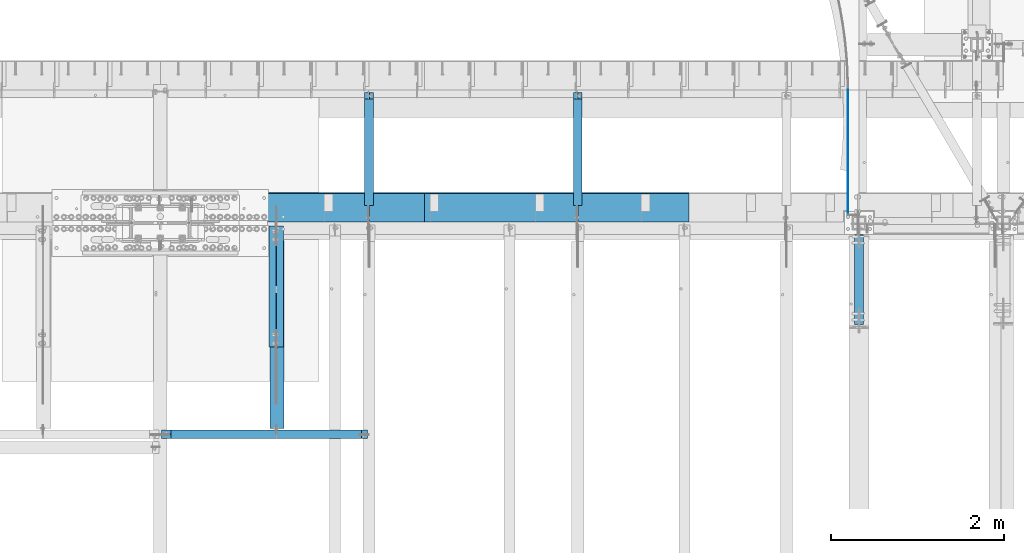
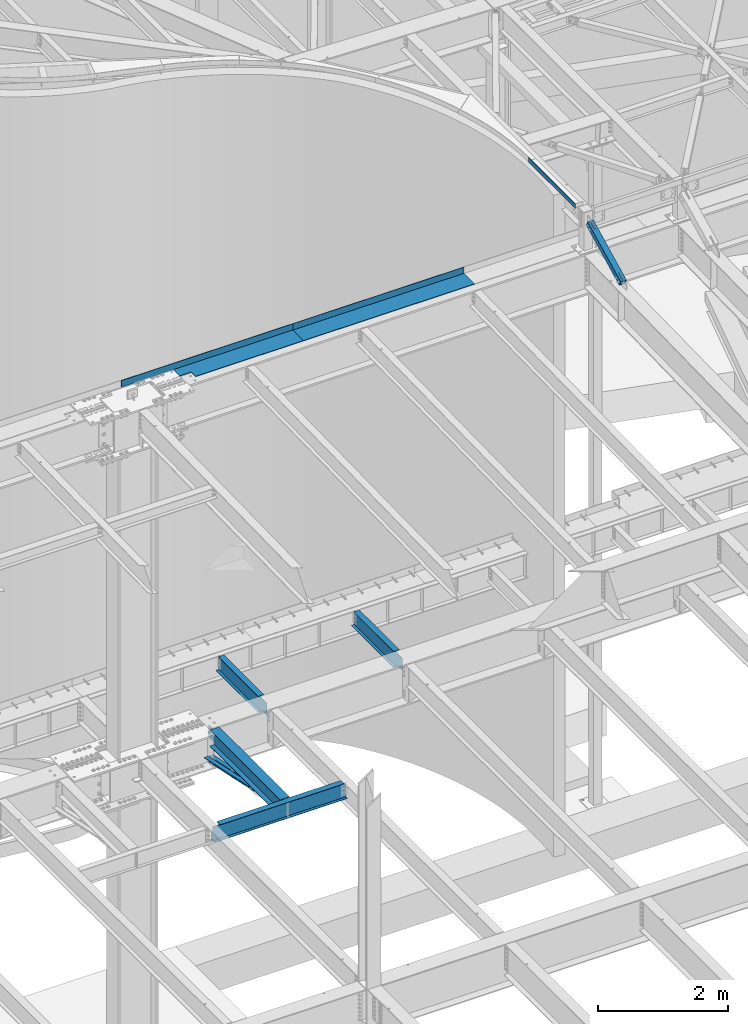
# One storey, part 1141 of 1763: 9 beams, 1 member, 8 elements without a shape of their own.
"""IFC2X3 building model written with IfcOpenShell, lengths in millimetres."""

from ifc_helpers import new_model, si_unit, frame, origin_with_axes, place, context, subcontext, project, spatial, faceted_brep, material, type_object, element, aggregate, save


model = new_model("IFC2X3")

# Units and contexts
model_context = context("Model", 3, precision=1e-05, world=origin_with_axes())
body_context = subcontext(model_context, "Body", "Model", "MODEL_VIEW")
ifc_project = project(units=[si_unit("LENGTHUNIT", "METRE", prefix="MILLI"), si_unit("AREAUNIT", "SQUARE_METRE"), si_unit("VOLUMEUNIT", "CUBIC_METRE"), si_unit("MASSUNIT", "GRAM", prefix="KILO"), si_unit("TIMEUNIT", "SECOND"), si_unit("PLANEANGLEUNIT", "RADIAN"), si_unit("SOLIDANGLEUNIT", "STERADIAN"), si_unit("THERMODYNAMICTEMPERATUREUNIT", "DEGREE_CELSIUS"), si_unit("LUMINOUSINTENSITYUNIT", "LUMEN")], contexts=[model_context])

# Site, building, storey
site_placement = place(None, origin_with_axes())
site = spatial("IfcSite", under=ifc_project, at=site_placement, CompositionType="ELEMENT")
building_placement = place(site_placement, origin_with_axes())
building = spatial("IfcBuilding", under=site, at=building_placement, Name="Undefined", CompositionType="ELEMENT")
storey_placement = place(building_placement, origin_with_axes())
storey = spatial("IfcBuildingStorey", under=building, at=storey_placement, Name="Undefined", CompositionType="ELEMENT", Elevation=0.0)

# Assembly, beam
assembly_1_placement = place(storey_placement, origin_with_axes())
assembly_1 = element("IfcElementAssembly", 1, at=assembly_1_placement, inside=storey, Name="BEAM", AssemblyPlace="NOTDEFINED", PredefinedType="RIGID_FRAME")
ifc_material_1 = material(Name="STEEL/A36")
beam_type_1 = type_object("IfcBeamType", PredefinedType="NOTDEFINED")
beam_1_placement = place(assembly_1_placement, frame((-41466.5130411433, 52209.6785679558, 12526.764063), z_axis=(0.0, 0.0, 1.0), x_axis=(0.0, 1.0, 0.0)))
beam_1 = element("IfcBeam", 2, at=beam_1_placement, type_object=beam_type_1, material=ifc_material_1, Name="PLATE", context=body_context, shape_type="Brep", body=[
    faceted_brep([(0.0, 3.17500000000291, -44.4500000000007), (0.0, 3.17500000000291, 44.4500000000007), (1448.55603526433, 3.17500000000291, 44.4500000000007), (1448.55603526433, 3.17500000000291, -44.4500000000007), (0.0, -3.17500000000291, 44.4500000000007), (1448.55603526433, -3.17500000000291, 44.4500000000007), (0.0, -3.17500000000291, -44.4500000000007), (1448.55603526433, -3.17500000000291, -44.4500000000007)], [[[0, 1, 2, 3]], [[1, 4, 5, 2]], [[4, 6, 7, 5]], [[6, 0, 3, 7]], [[5, 7, 3, 2]], [[6, 4, 1, 0]]]),
])
aggregate(assembly_1, [beam_1])

# Assembly, member
assembly_2_placement = place(storey_placement, origin_with_axes())
assembly_2 = element("IfcElementAssembly", 3, at=assembly_2_placement, inside=storey, Name="BEAM", AssemblyPlace="NOTDEFINED", PredefinedType="RIGID_FRAME")
ifc_material_2 = material()
member_type = type_object("IfcMemberType", Name="HSS4X4X1/2", PredefinedType="NOTDEFINED")
member_placement = place(assembly_2_placement, frame((-41338.5382217802, 50822.4448748991, 11720.6374724137), z_axis=(-1.0, 0.0, 0.0), x_axis=(0.0, 0.894427191199916, 0.447213595099959)))
member = element("IfcMember", 4, at=member_placement, type_object=member_type, material=ifc_material_2, Name="BEAM", ObjectType="HSS4X4X1/2", context=body_context, shape_type="Brep", body=[
    faceted_brep([(1312.61289971653, -50.8000000018983, -7.9375), (1312.61289971651, -38.1000000018903, -7.9375), (1161.80039971038, -38.1000000016793, -7.9375), (1161.8003997104, -50.8000000016891, -7.9375), (1158.762849966, -38.1000000016738, -7.33329378931012), (1158.76284996603, -50.8000000016782, -7.33329378931012), (1156.18773963476, -38.1000000016684, -5.61266007566883), (1156.18773963477, -50.8000000016764, -5.61266007566883), (1154.46710592113, -38.1000000016629, -3.03754974439653), (1154.46710592115, -50.8000000016727, -3.03754974439653), (1153.86289971044, -38.1000000016684, 0.0), (1153.86289971046, -50.8000000016746, 0.0), (1154.46710592113, -38.1000000016629, 3.03754974439653), (1154.46710592115, -50.8000000016727, 3.03754974439653), (1156.18773963476, -38.1000000016684, 5.61266007566883), (1156.18773963477, -50.8000000016764, 5.61266007566883), (1158.762849966, -38.1000000016738, 7.33329378931012), (1158.76284996603, -50.8000000016782, 7.33329378931012), (1161.80039971038, -38.1000000016793, 7.9375), (1161.8003997104, -50.8000000016891, 7.9375), (1312.61289971653, -50.8000000018983, 7.9375), (1312.61289971651, -38.1000000018903, 7.9375), (1312.61289971639, 38.0999999981505, -7.9375), (1312.61289971636, 50.7999999981585, -7.9375), (1161.80039971021, 50.7999999983731, -7.9375), (1161.80039971024, 38.0999999983687, -7.9375), (1158.76284996585, 50.7999999983786, -7.33329378931012), (1158.76284996586, 38.0999999983705, -7.33329378931012), (1156.18773963459, 50.7999999983804, -5.61266007566883), (1156.18773963462, 38.099999998376, -5.61266007566883), (1154.46710592096, 50.7999999983858, -3.03754974439653), (1154.46710592099, 38.0999999983778, -3.03754974439653), (1153.86289971027, 50.7999999983858, 0.0), (1153.86289971031, 38.0999999983796, 0.0), (1154.46710592096, 50.7999999983858, 3.03754974439653), (1154.46710592099, 38.0999999983778, 3.03754974439653), (1156.18773963459, 50.7999999983804, 5.61266007566883), (1156.18773963462, 38.099999998376, 5.61266007566883), (1158.76284996585, 50.7999999983786, 7.33329378931012), (1158.76284996586, 38.0999999983705, 7.33329378931012), (1161.80039971021, 50.7999999983731, 7.9375), (1161.80039971024, 38.0999999983687, 7.9375), (1312.61289971639, 38.0999999981505, 7.9375), (1312.61289971636, 50.7999999981585, 7.9375), (166.342448712407, -38.100000000255, 38.0999999999985), (166.342448712276, 38.0999999997875, 38.0999999999985), (1312.61289971639, 38.0999999981505, 38.0999999999985), (1312.61289971651, -38.1000000018903, 38.0999999999985), (322.767606017376, -38.1000000004806, 5.61266007592349), (320.192495686126, -38.1000000004788, 7.33329378956478), (317.154945941751, -38.1000000004733, 7.93750000025466), (166.342448712407, -38.100000000255, 7.93750000025466), (1312.61289971651, -38.1000000018903, -38.0999999999985), (166.342448712407, -38.100000000255, -38.0999999999985), (166.342448712407, -38.100000000255, -7.93749999974898), (317.154945941751, -38.1000000004715, -7.93749999987267), (320.192495686126, -38.1000000004769, -7.33329378918279), (322.767606017376, -38.1000000004806, -5.61266007554514), (324.488239731007, -38.1000000004842, -3.03754974427284), (325.092445941693, -38.1000000004842, 2.5465851649642e-10), (324.488239731007, -38.1000000004842, 3.03754974465119), (166.342448712276, 38.0999999997875, -38.0999999999985), (1312.61289971639, 38.0999999981505, -38.0999999999985), (166.342448712276, 38.0999999997875, 7.93750000025466), (166.342448712254, 50.7999999997955, 7.93750000025466), (317.154945941591, 50.7999999995791, 7.93750000025466), (317.15494594162, 38.0999999995711, 7.93750000025466), (320.192495685966, 50.7999999995736, 7.33329378956478), (320.192495685995, 38.0999999995693, 7.33329378956478), (322.767606017216, 50.7999999995718, 5.61266007592349), (322.767606017245, 38.0999999995638, 5.61266007592349), (324.488239730847, 50.7999999995682, 3.03754974465119), (324.488239730868, 38.0999999995638, 3.03754974465119), (325.092445941533, 50.7999999995682, 2.5465851649642e-10), (325.092445941555, 38.0999999995583, 2.5465851649642e-10), (324.488239730847, 50.7999999995682, -3.03754974427284), (324.488239730861, 38.0999999995602, -3.03754974427284), (322.767606017209, 50.79999999957, -5.61266007554514), (322.767606017245, 38.0999999995638, -5.61266007554514), (320.192495685966, 50.7999999995754, -7.33329378918279), (320.19249568598, 38.0999999995674, -7.33329378918279), (317.154945941591, 50.7999999995791, -7.93749999987267), (317.154945941606, 38.0999999995693, -7.93749999987267), (166.342448712254, 50.7999999997955, -7.93749999974898), (166.342448712276, 38.0999999997875, -7.93749999974898), (166.342448712254, 50.7999999997955, -50.7999999999993), (166.342448712421, -50.8000000002612, -50.7999999999993), (166.342448712421, -50.8000000002612, -7.93749999974898), (317.154945941773, -50.8000000004795, -7.93749999987267), (320.192495686155, -50.8000000004831, -7.33329378918279), (322.767606017391, -50.8000000004868, -5.61266007554514), (324.488239731028, -50.800000000494, -3.03754974427284), (325.092445941715, -50.8000000004904, 2.5465851649642e-10), (324.488239731028, -50.800000000494, 3.03754974465119), (322.767606017405, -50.8000000004849, 5.61266007592349), (320.192495686155, -50.8000000004849, 7.33329378956478), (317.154945941787, -50.8000000004795, 7.93750000025466), (166.342448712421, -50.8000000002612, 7.93750000025466), (166.342448712421, -50.8000000002612, 50.7999999999993), (166.342448712254, 50.7999999997955, 50.7999999999993), (1312.61289971653, -50.8000000018983, 50.7999999999993), (1312.61289971636, 50.7999999981585, 50.7999999999993), (1312.61289971636, 50.7999999981585, -50.7999999999993), (1312.61289971653, -50.8000000018983, -50.7999999999993)], [[[0, 1, 2, 3]], [[3, 2, 4, 5]], [[5, 4, 6, 7]], [[7, 6, 8, 9]], [[9, 8, 10, 11]], [[11, 10, 12, 13]], [[13, 12, 14, 15]], [[15, 14, 16, 17]], [[17, 16, 18, 19]], [[20, 19, 18, 21]], [[22, 23, 24, 25]], [[25, 24, 26, 27]], [[27, 26, 28, 29]], [[29, 28, 30, 31]], [[31, 30, 32, 33]], [[33, 32, 34, 35]], [[35, 34, 36, 37]], [[37, 36, 38, 39]], [[39, 38, 40, 41]], [[42, 41, 40, 43]], [[44, 45, 46, 47]], [[48, 49, 50, 51, 44, 47, 21, 18, 16, 14, 12, 10, 8, 6, 4, 2, 1, 52, 53, 54, 55, 56, 57, 58, 59, 60]], [[61, 53, 52, 62]], [[63, 64, 65, 66]], [[66, 65, 67, 68]], [[68, 67, 69, 70]], [[70, 69, 71, 72]], [[72, 71, 73, 74]], [[74, 73, 75, 76]], [[76, 75, 77, 78]], [[78, 77, 79, 80]], [[80, 79, 81, 82]], [[82, 81, 83, 84]], [[53, 61, 84, 83, 85, 86, 87, 54]], [[88, 55, 54, 87]], [[89, 56, 55, 88]], [[90, 57, 56, 89]], [[91, 58, 57, 90]], [[92, 59, 58, 91]], [[93, 60, 59, 92]], [[94, 48, 60, 93]], [[95, 49, 48, 94]], [[96, 50, 49, 95]], [[97, 51, 50, 96]], [[98, 99, 64, 63, 45, 44, 51, 97]], [[99, 98, 100, 101]], [[47, 46, 42, 43, 101, 100, 20, 21]], [[69, 67, 65, 64, 99, 101, 43, 40, 38, 36, 34, 32, 30, 28, 26, 24, 23, 102, 85, 83, 81, 79, 77, 75, 73, 71]], [[86, 85, 102, 103]], [[90, 89, 88, 87, 86, 103, 0, 3, 5, 7, 9, 11, 13, 15, 17, 19, 20, 100, 98, 97, 96, 95, 94, 93, 92, 91]], [[103, 102, 23, 22, 62, 52, 1, 0]], [[78, 80, 82, 84, 61, 62, 22, 25, 27, 29, 31, 33, 35, 37, 39, 41, 42, 46, 45, 63, 66, 68, 70, 72, 74, 76]]]),
])
aggregate(assembly_2, [member])

# Assembly, beams
assembly_3_placement = place(storey_placement, origin_with_axes())
assembly_3 = element("IfcElementAssembly", 5, at=assembly_3_placement, inside=storey, Name="ANGLE BRACE", AssemblyPlace="NOTDEFINED", PredefinedType="RIGID_FRAME")
beam_type_2 = type_object("IfcBeamType", Name="L4X3X5/16", PredefinedType="NOTDEFINED")
beam_2_placement = place(assembly_3_placement, frame((-48021.3122736983, 52076.9355387112, 4524.94833056974), z_axis=(0.0, -0.2072236520035, -0.978293595016513), x_axis=(0.0, -0.978293595016513, 0.207223652003498)))
beam_2 = element("IfcBeam", 6, at=beam_2_placement, type_object=beam_type_2, material=ifc_material_1, Name="ANGLE BRACE", ObjectType="L4X3X5/16", context=body_context, shape_type="Brep", body=[
    faceted_brep([(1.45519152283669e-10, 38.0999999999985, -50.7999999999993), (1.45519152283669e-10, 38.0999999999985, 50.7999999999993), (1427.46422513096, 38.0999999999985, 50.7999999991189), (1427.46422513096, 38.0999999999985, -50.8000000008396), (-7.27595761418343e-11, 30.1624999999985, 50.8000000000211), (1427.46422513096, 30.1624999999985, 50.7999999991189), (7.27595761418343e-11, 30.1624999999985, -42.8625000000175), (1427.46422513096, 30.1624999999985, -42.8625000008433), (7.27595761418343e-11, -38.0999999999985, -42.8625000000175), (1427.46422513096, -38.0999999999985, -42.8625000008433), (-1.23691279441118e-10, -38.1000000000022, -50.7999999999993), (1427.46422513096, -38.0999999999985, -50.8000000008396)], [[[0, 1, 2, 3]], [[1, 4, 5, 2]], [[4, 6, 7, 5]], [[6, 8, 9, 7]], [[8, 10, 11, 9]], [[10, 0, 3, 11]], [[5, 7, 9, 11, 3, 2]], [[10, 8, 6, 4, 1, 0]]]),
])
beam_3_placement = place(assembly_3_placement, frame((-48107.0372736984, 50680.4564530846, 4820.75267554856), z_axis=(0.0, -0.2072236520035, -0.978293595016513), x_axis=(0.0, 0.978293600950479, -0.20722362398951)))
beam_3 = element("IfcBeam", 7, at=beam_3_placement, type_object=beam_type_2, material=ifc_material_1, Name="ANGLE BRACE", ObjectType="L4X3X5/16", context=body_context, shape_type="Brep", body=[
    faceted_brep([(1.45519152283669e-10, 38.0999999999985, -50.7999999999993), (1.45519152283669e-10, 38.0999999999985, 50.7999999999993), (1427.42255777739, 38.0999999999985, 50.7999999995518), (1427.42255777754, 38.0999999999985, -50.8000000004868), (-7.27595761418343e-11, 30.1624999999985, 50.8000000000211), (1427.42255777739, 30.1624999999985, 50.7999999995518), (7.27595761418343e-11, 30.1624999999985, -42.8625000000175), (1427.42255777754, 30.1624999999985, -42.8625000004868), (7.27595761418343e-11, -38.0999999999985, -42.8625000000175), (1427.42255777754, -38.0999999999985, -42.8625000004868), (-1.23691279441118e-10, -38.1000000000022, -50.7999999999993), (1427.42255777754, -38.0999999999985, -50.8000000004868)], [[[0, 1, 2, 3]], [[1, 4, 5, 2]], [[4, 6, 7, 5]], [[6, 8, 9, 7]], [[8, 10, 11, 9]], [[10, 0, 3, 11]], [[5, 7, 9, 11, 3, 2]], [[10, 8, 6, 4, 1, 0]]]),
])
aggregate(assembly_3, [beam_2, beam_3])

assembly_4_placement = place(storey_placement, origin_with_axes())
assembly_4 = element("IfcElementAssembly", 8, at=assembly_4_placement, inside=storey, Name="BEAM", AssemblyPlace="NOTDEFINED", PredefinedType="RIGID_FRAME")
beam_type_3 = type_object("IfcBeamType", PredefinedType="NOTDEFINED")
beam_4_placement = place(assembly_4_placement, frame((-47875.2617736983, 52133.5000002128, 11752.2624917654), z_axis=(-1.0, 0.0, 0.0), x_axis=(0.0, 1.0, 0.0)))
beam_4 = element("IfcBeam", 9, at=beam_4_placement, type_object=beam_type_3, material=ifc_material_1, Name="BENT_PLATE", context=body_context, shape_type="Brep", body=[
    faceted_brep([(133.349999999999, -4.76250000000073, 395.288085937507), (133.349999999999, 4.76250000000073, 395.288085937507), (0.0, 4.76250000000073, 395.288085937507), (0.0, -4.76250000000073, 395.288085937507), (133.349999999999, -4.76250000000073, 598.487976074226), (133.349999999999, 4.76250000000073, 598.487976074226), (327.024987792975, -4.76250000000073, 598.487976074226), (327.02498779296, 4.76250000000073, 598.487976074226), (327.024987792967, -4.76250000000073, 1524.00000000001), (327.024987792967, 4.76250000000073, 1524.0), (327.024987792975, -4.76250000000073, -1524.0), (0.0, -4.76249999999982, -1524.0), (0.0, 4.76249999999982, -1524.0), (336.549987792969, 4.76250000000073, -1524.0), (336.549987792969, -122.237499999999, -1524.0), (327.024987792975, -122.237499999999, -1524.0), (336.549987792969, 4.76250000000073, 1524.0), (336.549987792969, -122.237499999999, 1524.0), (327.024987792975, -122.237499999999, 1524.0), (327.024987792975, -99.5375007629373, 1524.0)], [[[0, 1, 2, 3]], [[4, 5, 1, 0]], [[6, 7, 5, 4]], [[8, 9, 7, 6]], [[10, 11, 12, 13, 14, 15]], [[13, 16, 17, 14]], [[18, 15, 14, 17]], [[19, 8, 6, 10, 15, 18]], [[0, 3, 11, 10, 6, 4]], [[12, 11, 3, 2]], [[16, 13, 12, 2, 1, 5, 7, 9]], [[19, 18, 17, 16, 9, 8]]]),
])
beam_type_4 = type_object("IfcBeamType", PredefinedType="NOTDEFINED")
beam_5_placement = place(assembly_4_placement, frame((-44827.2617736983, 52133.5000002128, 11752.2624917654), z_axis=(-1.0, 0.0, 0.0), x_axis=(0.0, 1.0, 0.0)))
beam_5 = element("IfcBeam", 10, at=beam_5_placement, type_object=beam_type_4, material=ifc_material_1, Name="BENT_PLATE", context=body_context, shape_type="Brep", body=[
    faceted_brep([(0.0, -4.76249999999982, -1524.0), (0.0, -4.76249999999982, 1524.0), (0.0, 4.76249999999982, 1524.0), (0.0, 4.76249999999982, -1524.0), (336.549987792969, 4.76250000000073, 1524.0), (336.549987792969, 4.76250000000073, -1524.0), (327.024987792975, -4.76250000000073, -1524.0), (327.024987792967, -4.76250000000073, 1524.00000000001), (336.549987792969, -122.237499999999, 1524.0), (336.549987792969, -122.237499999999, -1524.0), (327.024987792975, -122.237499999999, 1524.0), (327.024987792975, -122.237499999999, -1524.0)], [[[0, 1, 2, 3]], [[3, 2, 4, 5]], [[1, 0, 6, 7]], [[5, 4, 8, 9]], [[4, 2, 1, 7, 10, 8]], [[7, 6, 11, 10]], [[6, 0, 3, 5, 9, 11]], [[10, 11, 9, 8]]]),
])
aggregate(assembly_4, [beam_4, beam_5])

# Assembly, beam
assembly_5_placement = place(storey_placement, origin_with_axes())
assembly_5 = element("IfcElementAssembly", 11, at=assembly_5_placement, inside=storey, Name="BEAM", AssemblyPlace="NOTDEFINED", PredefinedType="RIGID_FRAME")
ifc_material_3 = material(Name="STEEL/A992")
beam_type_5 = type_object("IfcBeamType", Name="W12X16", PredefinedType="NOTDEFINED")
beam_6_placement = place(assembly_5_placement, frame((-44584.903940365, 52120.8, 5041.9), z_axis=(0.0, 0.0, 1.0), x_axis=(0.0, 1.0, 0.0)))
beam_6 = element("IfcBeam", 12, at=beam_6_placement, type_object=beam_type_5, material=ifc_material_3, Name="BEAM", ObjectType="W12X16", context=body_context, shape_type="Brep", body=[
    faceted_brep([(20.6374999999971, -3.17500000000291, -114.3), (20.6374999999971, 3.17500000000291, -114.3), (192.087500190733, 3.17500000000291, -114.3), (192.087500190733, -3.17500000000291, -114.3), (196.94757970878, 3.17500000000291, -115.266729922588), (196.94757970878, -3.17500000000291, -115.266729922588), (201.067756176933, 3.17500000000291, -118.019743823066), (201.067756176933, -3.17500000000291, -118.019743823066), (203.820770077407, 3.17500000000291, -122.13992029122), (203.820770077407, -3.17500000000291, -122.13992029122), (204.787499999999, -3.17500000000291, -126.999999809265), (204.787499999999, 3.17500000000291, -126.999999809265), (204.787499999999, 3.17500000000291, -146.05), (204.787499999999, 50.8000000000029, -146.05), (204.787499999999, 50.8000000000029, -152.4), (204.787499999999, -50.8000000000029, -152.4), (204.787499999999, -50.8000000000029, -146.05), (204.787499999999, -3.17500000000291, -146.05), (1431.13125000001, 50.8000000000029, 146.05), (1431.13125000001, 3.17500000000291, 146.05), (204.787499999999, 3.17500000000291, 146.05), (204.787499999999, 50.8000000000029, 146.05), (192.087500190733, -3.17500000000291, 114.3), (192.087500190733, 3.17500000000291, 114.3), (20.6374999999971, 3.17500000000291, 114.3), (20.6374999999971, -3.17500000000291, 114.3), (196.94757970878, -3.17500000000291, 115.266729922588), (196.94757970878, 3.17500000000291, 115.266729922588), (201.067756176933, -3.17500000000291, 118.019743823066), (201.067756176933, 3.17500000000291, 118.019743823066), (203.820770077407, -3.17500000000291, 122.13992029122), (203.820770077407, 3.17500000000291, 122.13992029122), (204.787499999999, -3.17500000000291, 126.999999809265), (204.787499999999, 3.17500000000291, 126.999999809265), (1431.13125000001, -50.8000000000029, 152.4), (1431.13125000001, 50.8000000000029, 152.4), (204.787499999999, 50.8000000000029, 152.4), (204.787499999999, -50.8000000000029, 152.4), (1431.13125000001, -50.8000000000029, 146.05), (204.787499999999, -50.8000000000029, 146.05), (1431.13125000001, -3.17500000000291, 146.05), (204.787499999999, -3.17500000000291, 146.05), (1431.13125000001, -3.17500000000291, 139.440001487732), (1431.13125000001, 3.17500000000291, 139.440001487732), (1432.0979799226, -3.17500000000291, 134.579921969686), (1432.0979799226, 3.17500000000291, 134.579921969686), (1434.85099382307, -3.17500000000291, 130.459745501533), (1434.85099382307, 3.17500000000291, 130.459745501533), (1438.97117029122, -3.17500000000291, 127.706731601054), (1438.97117029122, 3.17500000000291, 127.706731601054), (1443.83124980927, -3.17500000000291, 126.740001678467), (1443.83124980927, 3.17500000000291, 126.740001678467), (1507.33125, -3.17500000000291, 126.740001678467), (1507.33125, 3.17500000000291, 126.740001678467), (1507.33125, -3.17500000000291, -146.05), (1507.33125, -50.8000000000029, -146.05), (1507.33125, -50.8000000000029, -152.4), (1507.33125, 50.8000000000029, -152.4), (1507.33125, 50.8000000000029, -146.05), (1507.33125, 3.17500000000291, -146.05)], [[[0, 1, 2, 3]], [[3, 2, 4, 5]], [[5, 4, 6, 7]], [[7, 6, 8, 9]], [[10, 11, 12, 13, 14, 15, 16, 17]], [[9, 8, 11, 10]], [[18, 19, 20, 21]], [[22, 23, 24, 25]], [[26, 27, 23, 22]], [[28, 29, 27, 26]], [[30, 31, 29, 28]], [[32, 33, 31, 30]], [[34, 35, 36, 37]], [[38, 34, 37, 39]], [[40, 38, 39, 41]], [[37, 36, 21, 20, 33, 32, 41, 39]], [[35, 18, 21, 36]], [[34, 38, 40, 42, 43, 19, 18, 35]], [[44, 45, 43, 42]], [[46, 47, 45, 44]], [[48, 49, 47, 46]], [[50, 51, 49, 48]], [[52, 53, 51, 50]], [[54, 55, 56, 57, 58, 59, 53, 52]], [[55, 54, 17, 16]], [[56, 55, 16, 15]], [[57, 56, 15, 14]], [[58, 57, 14, 13]], [[59, 58, 13, 12]], [[6, 4, 2, 1, 24, 23, 27, 29, 31, 33, 20, 19, 43, 45, 47, 49, 51, 53, 59, 12, 11, 8]], [[25, 24, 1, 0]], [[54, 52, 50, 48, 46, 44, 42, 40, 41, 32, 30, 28, 26, 22, 25, 0, 3, 5, 7, 9, 10, 17]]]),
])
aggregate(assembly_5, [beam_6])

assembly_6_placement = place(storey_placement, origin_with_axes())
assembly_6 = element("IfcElementAssembly", 13, at=assembly_6_placement, inside=storey, Name="BEAM", AssemblyPlace="NOTDEFINED", PredefinedType="RIGID_FRAME")
beam_7_placement = place(assembly_6_placement, frame((-46993.6706070317, 52120.8, 5041.9), z_axis=(0.0, 0.0, 1.0), x_axis=(0.0, 1.0, 0.0)))
beam_7 = element("IfcBeam", 14, at=beam_7_placement, type_object=beam_type_5, material=ifc_material_3, Name="BEAM", ObjectType="W12X16", context=body_context, shape_type="Brep", body=[
    faceted_brep([(20.6374999999971, -3.17500000000291, -114.3), (20.6374999999971, 3.17500000000291, -114.3), (192.087500190733, 3.17500000000291, -114.3), (192.087500190733, -3.17500000000291, -114.3), (196.94757970878, 3.17500000000291, -115.266729922588), (196.94757970878, -3.17500000000291, -115.266729922588), (201.067756176933, 3.17500000000291, -118.019743823066), (201.067756176933, -3.17500000000291, -118.019743823066), (203.820770077407, 3.17500000000291, -122.13992029122), (203.820770077407, -3.17500000000291, -122.13992029122), (204.787499999999, -3.17500000000291, -126.999999809265), (204.787499999999, 3.17500000000291, -126.999999809265), (204.787499999999, 3.17500000000291, -146.05), (204.787499999999, 50.8000000000029, -146.05), (204.787499999999, 50.8000000000029, -152.4), (204.787499999999, -50.8000000000029, -152.4), (204.787499999999, -50.8000000000029, -146.05), (204.787499999999, -3.17500000000291, -146.05), (1431.13125000001, 50.8000000000029, 146.05), (1431.13125000001, 3.17500000000291, 146.05), (204.787499999999, 3.17500000000291, 146.05), (204.787499999999, 50.8000000000029, 146.05), (192.087500190733, -3.17500000000291, 114.3), (192.087500190733, 3.17500000000291, 114.3), (20.6374999999971, 3.17500000000291, 114.3), (20.6374999999971, -3.17500000000291, 114.3), (196.94757970878, -3.17500000000291, 115.266729922588), (196.94757970878, 3.17500000000291, 115.266729922588), (201.067756176933, -3.17500000000291, 118.019743823066), (201.067756176933, 3.17500000000291, 118.019743823066), (203.820770077407, -3.17500000000291, 122.13992029122), (203.820770077407, 3.17500000000291, 122.13992029122), (204.787499999999, -3.17500000000291, 126.999999809265), (204.787499999999, 3.17500000000291, 126.999999809265), (1431.13125000001, -50.8000000000029, 152.4), (1431.13125000001, 50.8000000000029, 152.4), (204.787499999999, 50.8000000000029, 152.4), (204.787499999999, -50.8000000000029, 152.4), (1431.13125000001, -50.8000000000029, 146.05), (204.787499999999, -50.8000000000029, 146.05), (1431.13125000001, -3.17500000000291, 146.05), (204.787499999999, -3.17500000000291, 146.05), (1431.13125000001, -3.17500000000291, 139.440001487732), (1431.13125000001, 3.17500000000291, 139.440001487732), (1432.0979799226, -3.17500000000291, 134.579921969686), (1432.0979799226, 3.17500000000291, 134.579921969686), (1434.85099382307, -3.17500000000291, 130.459745501533), (1434.85099382307, 3.17500000000291, 130.459745501533), (1438.97117029122, -3.17500000000291, 127.706731601054), (1438.97117029122, 3.17500000000291, 127.706731601054), (1443.83124980927, -3.17500000000291, 126.740001678467), (1443.83124980927, 3.17500000000291, 126.740001678467), (1507.33125, -3.17500000000291, 126.740001678467), (1507.33125, 3.17500000000291, 126.740001678467), (1507.33125, -3.17500000000291, -146.05), (1507.33125, -50.8000000000029, -146.05), (1507.33125, -50.8000000000029, -152.4), (1507.33125, 50.8000000000029, -152.4), (1507.33125, 50.8000000000029, -146.05), (1507.33125, 3.17500000000291, -146.05)], [[[0, 1, 2, 3]], [[3, 2, 4, 5]], [[5, 4, 6, 7]], [[7, 6, 8, 9]], [[10, 11, 12, 13, 14, 15, 16, 17]], [[9, 8, 11, 10]], [[18, 19, 20, 21]], [[22, 23, 24, 25]], [[26, 27, 23, 22]], [[28, 29, 27, 26]], [[30, 31, 29, 28]], [[32, 33, 31, 30]], [[34, 35, 36, 37]], [[38, 34, 37, 39]], [[40, 38, 39, 41]], [[37, 36, 21, 20, 33, 32, 41, 39]], [[35, 18, 21, 36]], [[34, 38, 40, 42, 43, 19, 18, 35]], [[44, 45, 43, 42]], [[46, 47, 45, 44]], [[48, 49, 47, 46]], [[50, 51, 49, 48]], [[52, 53, 51, 50]], [[54, 55, 56, 57, 58, 59, 53, 52]], [[55, 54, 17, 16]], [[56, 55, 16, 15]], [[57, 56, 15, 14]], [[58, 57, 14, 13]], [[59, 58, 13, 12]], [[6, 4, 2, 1, 24, 23, 27, 29, 31, 33, 20, 19, 43, 45, 47, 49, 51, 53, 59, 12, 11, 8]], [[25, 24, 1, 0]], [[54, 52, 50, 48, 46, 44, 42, 40, 41, 32, 30, 28, 26, 22, 25, 0, 3, 5, 7, 9, 10, 17]]]),
])
aggregate(assembly_6, [beam_7])

assembly_7_placement = place(storey_placement, origin_with_axes())
assembly_7 = element("IfcElementAssembly", 15, at=assembly_7_placement, inside=storey, Name="BEAM", AssemblyPlace="NOTDEFINED", PredefinedType="RIGID_FRAME")
beam_type_6 = type_object("IfcBeamType", Name="W12X26", PredefinedType="NOTDEFINED")
beam_8_placement = place(assembly_7_placement, frame((-48056.2372736984, 49682.4, 5038.725), z_axis=(0.0, 0.0, 1.0), x_axis=(0.0, 1.0, 0.0)))
beam_8 = element("IfcBeam", 16, at=beam_8_placement, type_object=beam_type_6, material=ifc_material_3, Name="BEAM", ObjectType="W12X26", context=body_context, shape_type="Brep", body=[
    faceted_brep([(2233.6125, -3.17500000000291, -146.05), (2233.6125, -82.5500000000029, -146.05), (2233.6125, -82.5500000000029, -155.575), (2233.6125, 82.5500000000029, -155.575), (2233.6125, 82.5500000000029, -146.05), (2233.6125, 3.17500000000291, -146.05), (2233.6125, 3.17500000000291, -123.824999809265), (2233.6125, -3.17500000000291, -123.824999809265), (2234.57922992259, 3.17500000000291, -118.96492029122), (2234.57922992259, -3.17500000000291, -118.96492029122), (2237.33224382307, 3.17500000000291, -114.844743823066), (2237.33224382307, -3.17500000000291, -114.844743823066), (2241.45242029122, 3.17500000000291, -112.091729922588), (2241.45242029122, -3.17500000000291, -112.091729922588), (2246.31249980927, 3.17500000000291, -111.125), (2246.31249980927, -3.17500000000291, -111.125), (2417.7625, -3.17500000000291, -111.125), (2417.7625, 3.17500000000291, -111.125), (65.8812499999913, 3.17500000000291, 146.05), (65.8812499999913, 82.5500000000029, 146.05), (2233.6125, 82.5500000000029, 146.05), (2233.6125, 3.17500000000291, 146.05), (65.8812499999913, -3.17500000000291, -123.824999809265), (65.8812499999913, 3.17500000000291, -123.824999809265), (65.8812499999913, 3.17500000000291, -146.05), (65.8812499999913, 82.5500000000029, -146.05), (65.8812499999913, 82.5500000000029, -155.575), (65.8812499999913, -82.5500000000029, -155.575), (65.8812499999913, -82.5500000000029, -146.05), (65.8812499999913, -3.17500000000291, -146.05), (64.9145200774001, -3.17500000000291, -118.96492029122), (64.9145200774001, 3.17500000000291, -118.96492029122), (62.1615061769262, -3.17500000000291, -114.844743823066), (62.1615061769262, 3.17500000000291, -114.844743823066), (58.0413297087725, -3.17500000000291, -112.091729922588), (58.0413297087725, 3.17500000000291, -112.091729922588), (53.1812501907261, -3.17500000000291, -111.125), (53.1812501907261, 3.17500000000291, -111.125), (15.0812499999956, -3.17500000000291, -111.125), (15.0812499999956, 3.17500000000291, -111.125), (15.0812499999956, -3.17500000000291, 117.475), (15.0812499999956, 3.17500000000291, 117.475), (53.1812501907261, -3.17500000000291, 117.475), (53.1812501907261, 3.17500000000291, 117.475), (58.0413297087725, -3.17500000000291, 118.441729922588), (58.0413297087725, 3.17500000000291, 118.441729922588), (62.1615061769262, -3.17500000000291, 121.194743823066), (62.1615061769262, 3.17500000000291, 121.194743823066), (64.9145200774001, -3.17500000000291, 125.31492029122), (64.9145200774001, 3.17500000000291, 125.31492029122), (65.8812499999913, -3.17500000000291, 130.174999809266), (65.8812499999913, 3.17500000000291, 130.174999809266), (65.8812499999913, -82.5500000000029, 155.575), (65.8812499999913, 82.5500000000029, 155.575), (65.8812499999913, -3.17500000000291, 146.05), (65.8812499999913, -82.5500000000029, 146.05), (2233.6125, -3.17500000000291, 146.05), (2233.6125, -82.5500000000029, 146.05), (2233.6125, -82.5500000000029, 155.575), (2233.6125, 82.5500000000029, 155.575), (2233.6125, -3.17500000000291, 123.824999809265), (2233.6125, 3.17500000000291, 123.824999809265), (2234.57922992259, -3.17500000000291, 118.96492029122), (2234.57922992259, 3.17500000000291, 118.96492029122), (2237.33224382307, -3.17500000000291, 114.844743823066), (2237.33224382307, 3.17500000000291, 114.844743823066), (2241.45242029122, -3.17500000000291, 112.091729922588), (2241.45242029122, 3.17500000000291, 112.091729922588), (2246.31249980927, -3.17500000000291, 111.125), (2246.31249980927, 3.17500000000291, 111.125), (2417.7625, -3.17500000000291, 111.125), (2417.7625, 3.17500000000291, 111.125)], [[[0, 1, 2, 3, 4, 5, 6, 7]], [[7, 6, 8, 9]], [[9, 8, 10, 11]], [[11, 10, 12, 13]], [[13, 12, 14, 15]], [[16, 15, 14, 17]], [[18, 19, 20, 21]], [[22, 23, 24, 25, 26, 27, 28, 29]], [[30, 31, 23, 22]], [[32, 33, 31, 30]], [[34, 35, 33, 32]], [[36, 37, 35, 34]], [[38, 39, 37, 36]], [[40, 41, 39, 38]], [[42, 43, 41, 40]], [[44, 45, 43, 42]], [[46, 47, 45, 44]], [[48, 49, 47, 46]], [[50, 51, 49, 48]], [[52, 53, 19, 18, 51, 50, 54, 55]], [[55, 54, 56, 57]], [[52, 55, 57, 58]], [[53, 52, 58, 59]], [[19, 53, 59, 20]], [[58, 57, 56, 60, 61, 21, 20, 59]], [[62, 63, 61, 60]], [[64, 65, 63, 62]], [[66, 67, 65, 64]], [[68, 69, 67, 66]], [[70, 71, 69, 68]], [[71, 70, 16, 17]], [[12, 10, 8, 6, 5, 24, 23, 31, 33, 35, 37, 39, 41, 43, 45, 47, 49, 51, 18, 21, 61, 63, 65, 67, 69, 71, 17, 14]], [[25, 24, 5, 4]], [[26, 25, 4, 3]], [[27, 26, 3, 2]], [[28, 27, 2, 1]], [[29, 28, 1, 0]], [[70, 68, 66, 64, 62, 60, 56, 54, 50, 48, 46, 44, 42, 40, 38, 36, 34, 32, 30, 22, 29, 0, 7, 9, 11, 13, 15, 16]]]),
])
aggregate(assembly_7, [beam_8])

assembly_8_placement = place(storey_placement, origin_with_axes())
assembly_8 = element("IfcElementAssembly", 17, at=assembly_8_placement, inside=storey, Name="BEAM", AssemblyPlace="NOTDEFINED", PredefinedType="RIGID_FRAME")
beam_type_7 = type_object("IfcBeamType", Name="W12X14", PredefinedType="NOTDEFINED")
beam_9_placement = place(assembly_8_placement, frame((-49402.4372736983, 49682.4, 5043.4875), z_axis=(0.0, 0.0, 1.0), x_axis=(1.0, 0.0, 0.0)))
beam_9 = element("IfcBeam", 18, at=beam_9_placement, type_object=beam_type_7, material=ifc_material_3, Name="BEAM", ObjectType="W12X14", context=body_context, shape_type="Brep", body=[
    faceted_brep([(111.918750190736, -2.38124999999854, 118.802501678467), (111.918750190736, 2.38124999999854, 118.802501678467), (16.6687499999971, 2.38124999999854, 118.802501678467), (16.6687499999971, -2.38124999999854, 118.802501678467), (116.778829708783, -2.38124999999854, 119.769231601054), (116.778829708783, 2.38124999999854, 119.769231601054), (120.899006176936, -2.38124999999854, 122.522245501533), (120.899006176936, 2.38124999999854, 122.522245501533), (123.65202007741, -2.38124999999854, 126.642421969686), (123.65202007741, 2.38124999999854, 126.642421969686), (124.618750000001, -2.38124999999854, 131.502501487732), (124.618750000001, 2.38124999999854, 131.502501487732), (124.618750000001, -50.8000000000029, 150.8125), (124.618750000001, 50.8000000000029, 150.8125), (124.618750000001, 50.8000000000029, 144.4625), (124.618750000001, 2.38124999999854, 144.4625), (124.618750000001, -2.38124999999854, 144.4625), (124.618750000001, -50.8000000000029, 144.4625), (16.6687499999971, -2.38124999999854, -144.4625), (16.6687499999898, -50.7999999999993, -144.4625), (2392.89166666666, -50.8000000000029, -144.4625), (2392.89166666666, -2.38124999999854, -144.4625), (16.6687499999971, -50.8000000000029, -150.8125), (2392.89166666666, -50.8000000000029, -150.8125), (16.6687499999971, 50.8000000000029, -150.8125), (2392.89166666666, 50.8000000000029, -150.8125), (16.6687499999898, 50.7999999999993, -144.4625), (2392.89166666666, 50.8000000000029, -144.4625), (16.6687499999971, 2.38124999999854, -144.4625), (2392.89166666666, 2.38124999999854, -144.4625), (2392.89166666666, 2.38124999999854, 125.152501678466), (2392.89166666666, -2.38124999999854, 125.152501678466), (2335.74166647593, 2.38124999999854, 125.152501678466), (2335.74166647593, -2.38124999999854, 125.152501678466), (2330.88158695788, 2.38124999999854, 126.119231601054), (2330.88158695788, -2.38124999999854, 126.119231601054), (2326.76141048973, 2.38124999999854, 128.872245501532), (2326.76141048973, -2.38124999999854, 128.872245501532), (2324.00839658926, 2.38124999999854, 132.992421969686), (2324.00839658926, -2.38124999999854, 132.992421969686), (2323.04166666666, 2.38124999999854, 137.852501487731), (2323.04166666666, -2.38124999999854, 137.852501487731), (2323.04166666666, -50.8000000000029, 150.8125), (2323.04166666666, -50.8000000000029, 144.4625), (2323.04166666666, -2.38124999999854, 144.4625), (2323.04166666666, 2.38124999999854, 144.4625), (2323.04166666666, 50.8000000000029, 144.4625), (2323.04166666666, 50.8000000000029, 150.8125)], [[[0, 1, 2, 3]], [[4, 5, 1, 0]], [[6, 7, 5, 4]], [[8, 9, 7, 6]], [[10, 11, 9, 8]], [[12, 13, 14, 15, 11, 10, 16, 17]], [[18, 19, 20, 21]], [[19, 22, 23, 20]], [[22, 24, 25, 23]], [[24, 26, 27, 25]], [[26, 28, 29, 27]], [[21, 20, 23, 25, 27, 29, 30, 31]], [[31, 30, 32, 33]], [[33, 32, 34, 35]], [[35, 34, 36, 37]], [[37, 36, 38, 39]], [[39, 38, 40, 41]], [[42, 43, 44, 41, 40, 45, 46, 47]], [[43, 42, 12, 17]], [[44, 43, 17, 16]], [[8, 6, 4, 0, 3, 18, 21, 31, 33, 35, 37, 39, 41, 44, 16, 10]], [[28, 26, 24, 22, 19, 18, 3, 2]], [[45, 40, 38, 36, 34, 32, 30, 29, 28, 2, 1, 5, 7, 9, 11, 15]], [[46, 45, 15, 14]], [[47, 46, 14, 13]], [[42, 47, 13, 12]]]),
])
aggregate(assembly_8, [beam_9])

save(model, "model.ifc")
